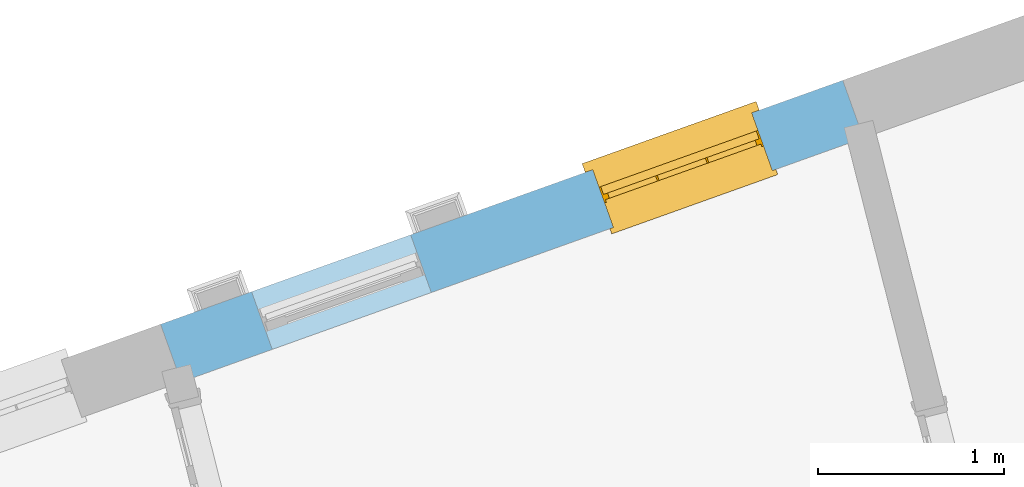
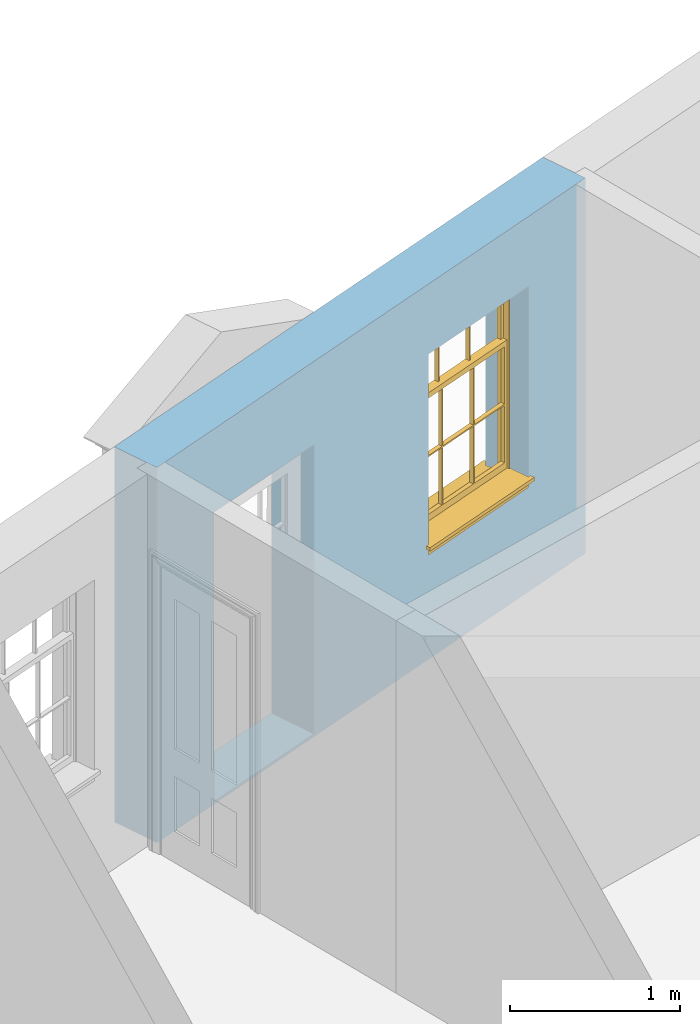
# One storey, part 11 of 15: 1 window, 2 openings, plus 1 element that does not belong to this part.
"""IFC2X3 building model written with IfcOpenShell, lengths in metres."""

from ifc_helpers import new_model, si_unit, frame, origin, place, context, subcontext, project, spatial, polyline, outline, extrude, faceted_brep, material, layer, layer_set, layer_usage, element, fill, save


model = new_model("IFC2X3")

# Units and contexts
model_context = context("Model", 3, world=origin())
body_context = subcontext(model_context, "Body", "Model", "MODEL_VIEW")
ifc_project = project(units=[si_unit("PLANEANGLEUNIT", "RADIAN"), si_unit("MASSUNIT", "GRAM", prefix="KILO"), si_unit("FORCEUNIT", "NEWTON", prefix="KILO"), si_unit("LENGTHUNIT", "METRE")], contexts=[model_context])

# Site, building, storey
site_placement = place(None, origin())
site = spatial("IfcSite", under=ifc_project, at=site_placement, CompositionType="ELEMENT")
building_placement = place(None, origin())
building = spatial("IfcBuilding", under=site, at=building_placement, Name="Building plot-13", CompositionType="ELEMENT")
storey_placement = place(None, frame((0.0, 0.0, 4.0)))
storey = spatial("IfcBuildingStorey", under=building, at=storey_placement, Name="Floor 0", CompositionType="ELEMENT", Elevation=4.0)

# Wall, openings, window
ifc_material = material(Name="Masonry")
ifc_layer = layer(ifc_material, 0.33, ventilated=False)
ifc_layer_set = layer_set([ifc_layer], Name="My Wall")
ifc_layer_usage = layer_usage(ifc_layer_set, "AXIS2", "NEGATIVE", 0.08)
wall_placement = place(storey_placement, origin())
wall = element("IfcWallStandardCase", 1, at=wall_placement, inside=storey, material=ifc_layer_usage, Name="exterior", context=body_context, shape_type="SweptSolid", body=[
    extrude(outline(polyline([(75.765136209946, 51.0653233722537), (75.6540271002417, 51.3760559996695), (71.9792289491637, 50.0620531725284), (72.090338058868, 49.7513205451126), (75.765136209946, 51.0653233722537)])), origin(), (0.0, 0.0, 1.0), 2.7),
])
opening_1_placement = place(storey_placement, frame((0.0, 0.0, 0.75)))
opening_1 = element("IfcOpeningElement", 2, at=opening_1_placement, cuts=wall, Name="Opening", ObjectType="Opening", context=body_context, shape_type="SweptSolid", body=[
    extrude(outline(polyline([(75.163761942697, 51.2007511865675), (74.3068931822474, 50.894359399201), (74.4180022919517, 50.5836267717852), (75.2748710524013, 50.8900185591517), (75.163761942697, 51.2007511865675)])), origin(), (0.0, 0.0, 1.0), 1.445),
])
opening_2_placement = place(storey_placement, frame((0.0, 0.0, 0.0199999999999996)))
element("IfcOpeningElement", 3, at=opening_2_placement, cuts=wall, Name="Opening", ObjectType="Opening", context=body_context, shape_type="SweptSolid", body=[
    extrude(outline(polyline([(73.326362867158, 50.5437497729969), (72.4694941067084, 50.2373579856305), (72.5806032164127, 49.9266253582147), (73.4374719768623, 50.2330171455811), (73.326362867158, 50.5437497729969)])), origin(), (0.0, 0.0, 1.0), 2.08),
])
window_placement = place(storey_placement, frame((75.2479355106548, 50.9653476809494, 0.75), z_axis=(0.0, 0.0, 1.0), x_axis=(-0.856868760449572, -0.306391787366429, 0.0)))
window = element("IfcWindow", 4, at=window_placement, inside=storey, Name="circulation street window", OverallHeight=1.445, OverallWidth=0.91, context=body_context, shape_type="Brep", held_by="IfcProductRepresentation", body=[
    faceted_brep([(0.876875, -0.105, 0.999097), (0.876875, -0.105, 1.411875), (0.9, -0.105, 1.435), (0.033125, -0.105, 1.411875), (0.033125, -0.105, 0.999097), (0.01, -0.105, 1.435), (0.033125, -0.135, 1.411875), (0.01, -0.135, 1.435), (0.033125, -0.135, 0.999097), (0.876875, -0.135, 1.411875), (0.876875, -0.135, 0.999097), (0.9, -0.135, 1.435), (0.033125, -0.105, 0.960972), (0.01, -0.105, 0.960972), (0.033125, -0.105, 0.548195), (0.876875, -0.105, 0.960972), (0.876875, -0.105, 0.548195), (0.9, -0.105, 0.960972), (0.876875, -0.105, 0.538195), (0.876875, -0.105, 0.125417), (0.9, -0.105, 0.077167), (0.033125, -0.105, 0.125417), (0.033125, -0.105, 0.538195), (0.01, -0.105, 0.077167), (0.9, -0.135, 0.960972), (0.01, -0.135, 0.960972), (-0.0425, -0.25, 0.01), (-0.0425, -0.3, 0.001667), (0.0, -0.25, 0.01), (0.9525, -0.25, 0.01), (0.91, -0.25, 0.01), (0.9525, -0.3, 0.001667), (-0.02, 0.08, 0.077167), (0.0, 0.08, 0.077167), (-0.02, 0.11, 0.077167), (0.0, -0.06, 0.077167), (0.01, -0.06, 0.077167), (0.91, -0.06, 0.077167), (0.91, 0.08, 0.077167), (0.9, -0.06, 0.077167), (0.93, 0.08, 0.077167), (0.93, 0.11, 0.077167), (0.01, -0.105, 0.999097), (0.01, -0.075, 0.999097), (0.9, -0.105, 0.999097), (0.9, -0.075, 0.999097), (0.876875, -0.075, 0.125417), (0.876875, -0.075, 0.538195), (0.9, -0.075, 0.077167), (0.876875, -0.075, 0.548195), (0.876875, -0.075, 0.960972), (0.033125, -0.075, 0.125417), (0.01, -0.075, 0.077167), (0.033125, -0.075, 0.538195), (0.033125, -0.075, 0.960972), (0.033125, -0.075, 0.548195), (-0.02, 0.08, 0.052167), (-0.02, 0.11, 0.052167), (0.93, 0.11, 0.052167), (0.93, 0.08, 0.052167), (0.91, 0.08, 0.052167), (0.0, 0.08, 0.052167), (0.91, -0.15, 0.026667), (0.0, -0.15, 0.026667), (-0.0425, -0.3, -0.123333), (0.9525, -0.3, -0.123333), (-0.0425, -0.25, -0.123333), (0.9525, -0.25, -0.123333), (0.01, -0.06, 1.435), (0.9, -0.06, 1.435), (0.0, -0.06, 1.445), (0.91, -0.06, 1.445), (0.01, -0.15, 0.077167), (0.9, -0.15, 0.077167), (0.592292, -0.105, 0.125417), (0.592292, -0.075, 0.125417), (0.317708, -0.075, 0.125417), (0.317708, -0.105, 0.125417), (0.592292, -0.105, 0.548195), (0.317708, -0.105, 0.548195), (0.317708, -0.105, 0.538195), (0.592292, -0.105, 0.538195), (0.592292, -0.075, 0.548195), (0.317708, -0.075, 0.548195), (0.602292, -0.075, 0.548195), (0.602292, -0.105, 0.548195), (0.317708, -0.075, 0.538195), (0.307708, -0.075, 0.125417), (0.307708, -0.075, 0.538195), (0.602292, -0.075, 0.538195), (0.602292, -0.075, 0.125417), (0.592292, -0.075, 0.538195), (0.307708, -0.075, 0.548195), (0.317708, -0.075, 0.960972), (0.307708, -0.075, 0.960972), (0.602292, -0.075, 0.960972), (0.592292, -0.075, 0.960972), (0.307708, -0.105, 0.538195), (0.307708, -0.105, 0.125417), (0.307708, -0.105, 0.548195), (0.307708, -0.105, 0.960972), (0.592292, -0.105, 0.960972), (0.317708, -0.105, 0.960972), (0.602292, -0.105, 0.960972), (0.602292, -0.105, 0.538195), (0.602292, -0.105, 0.125417), (0.317708, -0.135, 1.411875), (0.307708, -0.135, 1.411875), (0.307708, -0.135, 0.999097), (0.317708, -0.135, 0.999097), (0.602292, -0.135, 1.411875), (0.592292, -0.135, 1.411875), (0.592292, -0.135, 0.999097), (0.602292, -0.135, 0.999097), (0.317708, -0.105, 0.999097), (0.307708, -0.105, 0.999097), (0.307708, -0.105, 1.411875), (0.317708, -0.105, 1.411875), (0.602292, -0.105, 0.999097), (0.592292, -0.105, 0.999097), (0.592292, -0.105, 1.411875), (0.602292, -0.105, 1.411875), (0.91, -0.15, 1.445), (0.9, -0.15, 1.435), (0.01, -0.15, 1.435), (0.0, -0.15, 1.445), (0.91, -0.25, 0.0), (0.0, -0.25, 0.0), (0.91, 0.08, 0.0), (0.0, 0.08, 0.0)], [[[0, 1, 2]], [[3, 4, 5]], [[6, 7, 8]], [[9, 10, 11]], [[12, 13, 14]], [[15, 16, 17]], [[18, 19, 20]], [[21, 22, 23]], [[24, 15, 17]], [[13, 12, 25]], [[26, 27, 28]], [[29, 30, 31]], [[32, 33, 34]], [[35, 36, 33]], [[37, 38, 39]], [[40, 41, 38]], [[42, 4, 43]], [[44, 45, 0]], [[46, 47, 48]], [[49, 50, 45]], [[51, 52, 53]], [[54, 55, 43]], [[38, 33, 36, 39]], [[41, 34, 33, 38]], [[56, 32, 34, 57]], [[57, 34, 41, 58]], [[58, 41, 40, 59]], [[57, 58, 60, 61]], [[52, 48, 39, 36]], [[62, 63, 28, 30]], [[27, 31, 30, 28]], [[27, 64, 65, 31]], [[66, 67, 65, 64]], [[2, 5, 68, 69]], [[68, 70, 71, 69]], [[20, 23, 72, 73]], [[73, 72, 63, 62]], [[74, 75, 76, 77]], [[78, 79, 80, 81]], [[78, 82, 83, 79]], [[16, 49, 84, 85]], [[86, 76, 87, 88]], [[89, 90, 75, 91]], [[92, 88, 53, 55]], [[82, 91, 86, 83]], [[93, 83, 92, 94]], [[95, 84, 82, 96]], [[89, 84, 49, 47]], [[97, 88, 87, 98]], [[22, 53, 88, 97]], [[81, 91, 75, 74]], [[80, 86, 91, 81]], [[77, 76, 86, 80]], [[99, 92, 55, 14]], [[100, 94, 92, 99]], [[101, 96, 82, 78]], [[79, 83, 93, 102]], [[85, 84, 95, 103]], [[104, 89, 47, 18]], [[105, 90, 89, 104]], [[104, 18, 16, 85]], [[80, 97, 98, 77]], [[104, 81, 74, 105]], [[103, 101, 78, 85]], [[99, 14, 22, 97]], [[102, 100, 99, 79]], [[106, 107, 108, 109]], [[110, 111, 112, 113]], [[114, 115, 116, 117]], [[118, 119, 120, 121]], [[107, 116, 115, 108]], [[111, 120, 119, 112]], [[109, 114, 117, 106]], [[113, 118, 121, 110]], [[85, 78, 81, 104]], [[84, 89, 91, 82]], [[83, 86, 88, 92]], [[79, 99, 97, 80]], [[109, 112, 119, 114]], [[102, 93, 96, 101]], [[106, 117, 120, 111]], [[98, 87, 51, 21]], [[6, 3, 116, 107]], [[110, 121, 1, 9]], [[19, 46, 90, 105]], [[26, 66, 64, 27]], [[29, 31, 65, 67]], [[25, 24, 112, 109]], [[11, 7, 106, 111]], [[75, 48, 52, 76]], [[43, 45, 96, 93]], [[45, 43, 114, 119]], [[5, 2, 120, 117]], [[24, 25, 102, 101]], [[42, 5, 4]], [[2, 44, 0]], [[49, 45, 48, 47]], [[52, 43, 55, 53]], [[14, 13, 23, 22]], [[20, 17, 16, 18]], [[24, 11, 10]], [[25, 8, 7]], [[8, 4, 3, 6]], [[9, 1, 0, 10]], [[15, 50, 49, 16]], [[18, 47, 46, 19]], [[21, 51, 53, 22]], [[14, 55, 54, 12]], [[44, 2, 69, 45]], [[68, 5, 42, 43]], [[36, 35, 70, 68]], [[39, 69, 71, 37]], [[62, 122, 123, 73]], [[63, 72, 124, 125]], [[8, 108, 115, 4]], [[113, 10, 0, 118]], [[94, 100, 12, 54]], [[17, 20, 73, 24]], [[72, 23, 13, 25]], [[52, 36, 68, 43]], [[69, 39, 48, 45]], [[11, 24, 73, 123]], [[7, 124, 72, 25]], [[23, 77, 98]], [[98, 21, 23]], [[105, 74, 20]], [[20, 19, 105]], [[20, 74, 77, 23]], [[113, 112, 24]], [[24, 10, 113]], [[25, 109, 108]], [[108, 8, 25]], [[110, 9, 11]], [[11, 111, 110]], [[7, 6, 107]], [[107, 106, 7]], [[5, 117, 116]], [[116, 3, 5]], [[121, 120, 2]], [[2, 1, 121]], [[11, 123, 124, 7]], [[122, 125, 124, 123]], [[43, 93, 94]], [[94, 54, 43]], [[96, 45, 95]], [[50, 95, 45]], [[15, 103, 95, 50]], [[48, 75, 90]], [[90, 46, 48]], [[87, 76, 52]], [[52, 51, 87]], [[103, 15, 24]], [[24, 101, 103]], [[100, 102, 25]], [[25, 12, 100]], [[115, 114, 43]], [[43, 4, 115]], [[118, 0, 45]], [[45, 119, 118]], [[71, 70, 125, 122]], [[70, 35, 63, 125]], [[122, 62, 37, 71]], [[126, 67, 66, 127]], [[60, 58, 59]], [[38, 60, 59, 40]], [[61, 56, 57]], [[32, 56, 61, 33]], [[61, 60, 128, 129]], [[62, 60, 38, 37]], [[126, 128, 60, 62]], [[33, 61, 63, 35]], [[61, 129, 127, 63]], [[128, 126, 127, 129]], [[28, 127, 66, 26]], [[63, 127, 28]], [[29, 67, 126, 30]], [[30, 126, 62]]]),
])
fill(opening_1, window)

save(model, "model.ifc")
